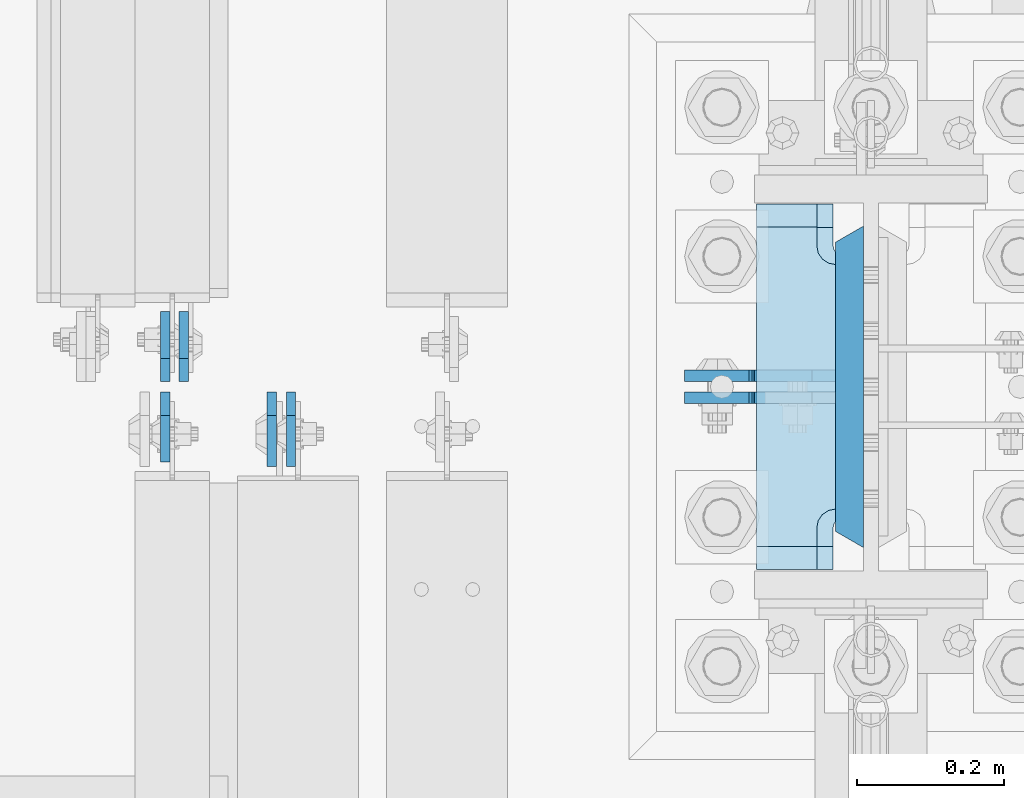
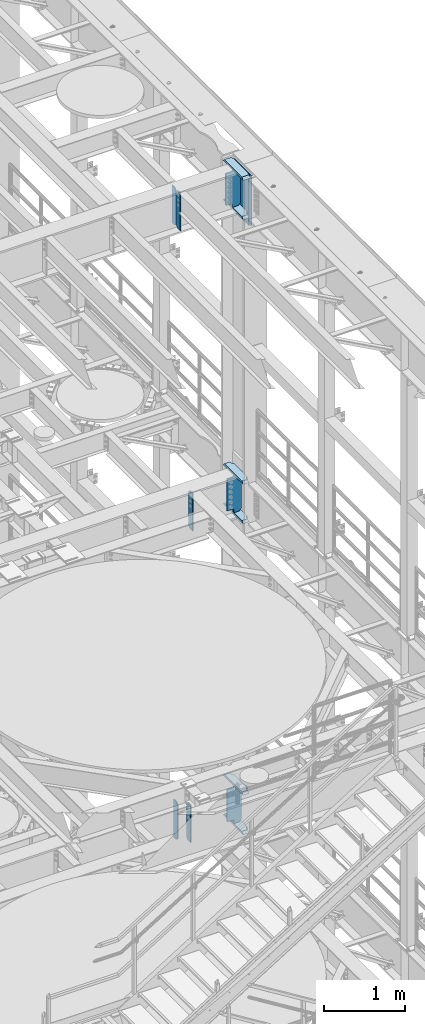
# One storey, part 1591 of 1876: 15 plates, 5 elements without a shape of their own.
"""IFC2X3 building model written with IfcOpenShell, lengths in millimetres."""

from ifc_helpers import new_model, si_unit, frame, origin_with_axes, place, context, subcontext, project, spatial, faceted_brep, material, type_object, element, aggregate, save


model = new_model("IFC2X3")

# Units and contexts
model_context = context("Model", 3, precision=1e-05, world=origin_with_axes())
body_context = subcontext(model_context, "Body", "Model", "MODEL_VIEW")
ifc_project = project(units=[si_unit("LENGTHUNIT", "METRE", prefix="MILLI"), si_unit("AREAUNIT", "SQUARE_METRE"), si_unit("VOLUMEUNIT", "CUBIC_METRE"), si_unit("MASSUNIT", "GRAM", prefix="KILO"), si_unit("TIMEUNIT", "SECOND"), si_unit("PLANEANGLEUNIT", "RADIAN"), si_unit("SOLIDANGLEUNIT", "STERADIAN"), si_unit("THERMODYNAMICTEMPERATUREUNIT", "DEGREE_CELSIUS"), si_unit("LUMINOUSINTENSITYUNIT", "LUMEN")], contexts=[model_context])

# Site, building, storey
site_placement = place(None, origin_with_axes())
site = spatial("IfcSite", under=ifc_project, at=site_placement, CompositionType="ELEMENT")
building_placement = place(site_placement, origin_with_axes())
building = spatial("IfcBuilding", under=site, at=building_placement, Name="Undefined", CompositionType="ELEMENT")
storey_placement = place(building_placement, origin_with_axes())
storey = spatial("IfcBuildingStorey", under=building, at=storey_placement, Name="Undefined", CompositionType="ELEMENT", Elevation=0.0)

# Assembly, plate
assembly_1_placement = place(storey_placement, origin_with_axes())
assembly_1 = element("IfcElementAssembly", 1, at=assembly_1_placement, inside=storey, Name="BEAM", AssemblyPlace="NOTDEFINED", PredefinedType="RIGID_FRAME")
ifc_material_1 = material(Name="STEEL/A36")
plate_type_1 = type_object("IfcPlateType", PredefinedType="NOTDEFINED")
plate_1_placement = place(assembly_1_placement, frame((6683.37499990463, 1531.14375, 12714.2875), z_axis=(0.0, 0.0, 1.0), x_axis=(0.0, 1.0, 0.0)))
plate_1 = element("IfcPlate", 2, at=plate_1_placement, type_object=plate_type_1, material=ifc_material_1, Name="PLATE", context=body_context, shape_type="Brep", body=[
    faceted_brep([(0.0, -6.34999999999991, 31.75), (0.0, -6.35000000000036, 538.162475585938), (0.0, 6.35000000000036, 538.162475585938), (0.0, 6.34999999999991, 31.75), (31.75, -6.35000000000036, 569.912475585938), (31.75, 6.35000000000036, 569.912475585938), (95.25, -6.35000000000036, 569.912475585938), (95.25, 6.35000000000036, 569.912475585938), (95.25, -6.35000000000036, 0.0), (95.25, 6.35000000000036, 0.0), (31.75, -6.34999999999991, 0.0), (31.75, 6.34999999999991, 0.0)], [[[0, 1, 2, 3]], [[1, 4, 5, 2]], [[4, 6, 7, 5]], [[6, 8, 9, 7]], [[8, 10, 11, 9]], [[10, 0, 3, 11]], [[5, 7, 9, 11, 3, 2]], [[10, 8, 6, 4, 1, 0]]]),
])

# Assembly, plates
assembly_2_placement = place(storey_placement, origin_with_axes())
assembly_2 = element("IfcElementAssembly", 3, at=assembly_2_placement, inside=storey, Name="BEAM", AssemblyPlace="NOTDEFINED", PredefinedType="RIGID_FRAME")
plate_2_placement = place(assembly_2_placement, frame((6657.97499990463, 1531.14375, 21959.8875), z_axis=(0.0, 0.0, 1.0), x_axis=(0.0, 1.0, 0.0)))
plate_2 = element("IfcPlate", 4, at=plate_2_placement, type_object=plate_type_1, material=ifc_material_1, Name="PLATE", context=body_context, shape_type="Brep", body=[
    faceted_brep([(0.0, -6.34999999999991, 31.75), (0.0, -6.35000000000036, 538.162475585938), (0.0, 6.35000000000036, 538.162475585938), (0.0, 6.34999999999991, 31.75), (31.75, -6.35000000000036, 569.912475585938), (31.75, 6.35000000000036, 569.912475585938), (95.25, -6.35000000000036, 569.912475585938), (95.25, 6.35000000000036, 569.912475585938), (95.25, -6.35000000000036, 0.0), (95.25, 6.35000000000036, 0.0), (31.75, -6.34999999999991, 0.0), (31.75, 6.34999999999991, 0.0)], [[[0, 1, 2, 3]], [[1, 4, 5, 2]], [[4, 6, 7, 5]], [[6, 8, 9, 7]], [[8, 10, 11, 9]], [[10, 0, 3, 11]], [[5, 7, 9, 11, 3, 2]], [[10, 8, 6, 4, 1, 0]]]),
])
plate_3_placement = place(assembly_2_placement, frame((6657.97499990463, 1516.85625, 21959.8875), z_axis=(0.0, 0.0, 1.0), x_axis=(0.0, -1.0, 0.0)))
plate_3 = element("IfcPlate", 5, at=plate_3_placement, type_object=plate_type_1, material=ifc_material_1, Name="PLATE", context=body_context, shape_type="Brep", body=[
    faceted_brep([(0.0, -6.34999999999991, 31.75), (0.0, -6.35000000000036, 538.162475585938), (0.0, 6.35000000000036, 538.162475585938), (0.0, 6.34999999999991, 31.75), (31.75, -6.35000000000036, 569.912475585938), (31.75, 6.35000000000036, 569.912475585938), (95.25, -6.35000000000036, 569.912475585938), (95.25, 6.35000000000036, 569.912475585938), (95.25, -6.35000000000036, 0.0), (95.25, 6.35000000000036, 0.0), (31.75, -6.34999999999991, 0.0), (31.75, 6.34999999999991, 0.0)], [[[0, 1, 2, 3]], [[1, 4, 5, 2]], [[4, 6, 7, 5]], [[6, 8, 9, 7]], [[8, 10, 11, 9]], [[10, 0, 3, 11]], [[5, 7, 9, 11, 3, 2]], [[10, 8, 6, 4, 1, 0]]]),
])
aggregate(assembly_2, [plate_2, plate_3])

# Plate
plate_type_2 = type_object("IfcPlateType", PredefinedType="NOTDEFINED")
plate_4_placement = place(assembly_1_placement, frame((6803.23124990463, 1516.85625, 12714.2875), z_axis=(0.0, 0.0, 1.0), x_axis=(0.0, -1.0, 0.0)))
plate_4 = element("IfcPlate", 6, at=plate_4_placement, type_object=plate_type_2, material=ifc_material_1, Name="PLATE", context=body_context, shape_type="Brep", body=[
    faceted_brep([(0.0, -6.34999999999991, 31.75), (0.0, -6.35000000000036, 538.162475585938), (0.0, 6.35000000000036, 538.162475585938), (0.0, 6.34999999999991, 31.75), (31.75, -6.35000000000036, 569.912475585938), (31.75, 6.35000000000036, 569.912475585938), (101.599998474121, -6.34999999999991, 569.912475585938), (101.599998474121, 6.34999999999991, 569.912475585938), (101.599998474121, -6.35000000000036, 0.0), (101.599998474121, 6.35000000000036, 0.0), (31.75, -6.34999999999991, 0.0), (31.75, 6.34999999999991, 0.0)], [[[0, 1, 2, 3]], [[1, 4, 5, 2]], [[4, 6, 7, 5]], [[6, 8, 9, 7]], [[8, 10, 11, 9]], [[10, 0, 3, 11]], [[5, 7, 9, 11, 3, 2]], [[10, 8, 6, 4, 1, 0]]]),
])

aggregate(assembly_1, [plate_1, plate_4])

# Assembly, plate
assembly_3_placement = place(storey_placement, origin_with_axes())
assembly_3 = element("IfcElementAssembly", 7, at=assembly_3_placement, inside=storey, Name="BEAM", AssemblyPlace="NOTDEFINED", PredefinedType="RIGID_FRAME")
plate_5_placement = place(assembly_3_placement, frame((6829.42481318188, 1516.85625, 17387.8875), z_axis=(0.0, 0.0, 1.0), x_axis=(0.0, -1.0, 0.0)))
plate_5 = element("IfcPlate", 8, at=plate_5_placement, type_object=plate_type_2, material=ifc_material_1, Name="PLATE", context=body_context, shape_type="Brep", body=[
    faceted_brep([(0.0, -6.34999999999991, 31.75), (0.0, -6.35000000000036, 538.162475585938), (0.0, 6.35000000000036, 538.162475585938), (0.0, 6.34999999999991, 31.75), (31.75, -6.35000000000036, 569.912475585938), (31.75, 6.35000000000036, 569.912475585938), (101.599998474121, -6.34999999999991, 569.912475585938), (101.599998474121, 6.34999999999991, 569.912475585938), (101.599998474121, -6.35000000000036, 0.0), (101.599998474121, 6.35000000000036, 0.0), (31.75, -6.34999999999991, 0.0), (31.75, 6.34999999999991, 0.0)], [[[0, 1, 2, 3]], [[1, 4, 5, 2]], [[4, 6, 7, 5]], [[6, 8, 9, 7]], [[8, 10, 11, 9]], [[10, 0, 3, 11]], [[5, 7, 9, 11, 3, 2]], [[10, 8, 6, 4, 1, 0]]]),
])
aggregate(assembly_3, [plate_5])

# Assembly, plates
assembly_4_placement = place(storey_placement, origin_with_axes())
assembly_4 = element("IfcElementAssembly", 9, at=assembly_4_placement, inside=storey, Name="COLUMN", AssemblyPlace="NOTDEFINED", PredefinedType="RIGID_FRAME")
ifc_material_2 = material(Name="STEEL/A572-GR.50")
plate_type_3 = type_object("IfcPlateType", PredefinedType="NOTDEFINED")
plate_6_placement = place(assembly_4_placement, frame((7590.63125, 1304.925, 22523.45), z_axis=(0.0, 1.0, 0.0), x_axis=(0.0, 0.0, -1.0)))
plate_6 = element("IfcPlate", 10, at=plate_6_placement, type_object=plate_type_3, material=ifc_material_2, Name="PLATE", context=body_context, shape_type="Brep", body=[
    faceted_brep([(0.0, 19.0500000000002, 416.152954742277), (0.0, -19.0500000000002, 438.149993896484), (742.950012207031, -19.0500000000002, 438.149993896484), (742.950012207031, 19.0500000000002, 416.152954742277), (742.950012207031, 19.0500000000002, 21.9970452577325), (0.0, 19.0500000000002, 21.9970452577367), (0.0, -19.0500000000002, 0.0), (742.950012207031, -19.0500000000002, 0.0)], [[[0, 1, 2, 3]], [[0, 3, 4, 5]], [[1, 0, 5, 6]], [[2, 1, 6, 7]], [[3, 2, 7, 4]], [[6, 5, 4, 7]]]),
])
ifc_material_3 = material(Name="STEEL/A572-50")
plate_type_4 = type_object("IfcPlateType", PredefinedType="NOTDEFINED")
plate_7_placement = place(assembly_4_placement, frame((7463.63125, 1773.2375, 17376.775012207), z_axis=(0.0, -1.0, 0.0), x_axis=(1.0, 0.0, 0.0)))
plate_7 = element("IfcPlate", 11, at=plate_7_placement, type_object=plate_type_4, material=ifc_material_3, Name="PLATE", context=body_context, shape_type="Brep", body=[
    faceted_brep([(82.5499973297119, -15.875, 498.475006103516), (82.5499973297119, 15.875, 467.025007631571), (0.0, 15.875, 467.025007631571), (0.0, -15.875, 498.475006103516), (82.5499973297119, 15.875, 31.449998471945), (82.5499973297119, -15.875, 0.0), (0.0, -15.875, 0.0), (0.0, 15.875, 31.449998471945), (82.5499973297119, 15.875, 57.1500034332275), (82.5499973297119, -15.875, 57.1500034332275), (84.4834571748879, -15.875, 66.8701624693188), (84.4834571748879, 15.875, 66.8701624693188), (89.9894849758439, -15.875, 75.1105154056261), (89.9894849758439, 15.875, 75.1105154056261), (98.2298379121512, -15.875, 80.616543206582), (98.2298379121512, 15.875, 80.616543206582), (107.949996948242, -15.875, 82.5500030517578), (107.949996948242, 15.875, 82.5500030517578), (107.949996948242, -15.875, 415.925003051758), (107.949996948242, 15.875, 415.925003051758), (98.2298379121512, -15.875, 417.858462896934), (98.2298379121512, 15.875, 417.858462896934), (89.9894849758439, -15.875, 423.36449069789), (89.9894849758439, 15.875, 423.36449069789), (84.483457174887, -15.875, 431.604843634197), (84.483457174887, 15.875, 431.604843634197), (82.5499973297119, -15.875, 441.325002670288), (82.5499973297119, 15.875, 441.325002670288)], [[[0, 1, 2, 3]], [[4, 5, 6, 7]], [[8, 9, 5, 4]], [[10, 9, 8, 11]], [[12, 10, 11, 13]], [[14, 12, 13, 15]], [[16, 14, 15, 17]], [[18, 16, 17, 19]], [[20, 18, 19, 21]], [[22, 20, 21, 23]], [[24, 22, 23, 25]], [[26, 24, 25, 27]], [[6, 5, 9, 10, 12, 14, 16, 18, 20, 22, 24, 26, 0, 3]], [[7, 6, 3, 2]], [[27, 25, 23, 21, 19, 17, 15, 13, 11, 8, 4, 7, 2, 1]], [[26, 27, 1, 0]]]),
])
plate_8_placement = place(assembly_4_placement, frame((7463.63125, 1773.2375, 17967.325), z_axis=(0.0, -1.0, 0.0), x_axis=(1.0, 0.0, 0.0)))
plate_8 = element("IfcPlate", 12, at=plate_8_placement, type_object=plate_type_4, material=ifc_material_3, Name="PLATE", context=body_context, shape_type="Brep", body=[
    faceted_brep([(82.5499973297119, -15.875, 498.475006103516), (82.5499973297119, 15.875, 467.025007631571), (0.0, 15.875, 467.025007631571), (0.0, -15.875, 498.475006103516), (82.5499973297119, 15.875, 31.449998471945), (82.5499973297119, -15.875, 0.0), (0.0, -15.875, 0.0), (0.0, 15.875, 31.449998471945), (82.5499973297119, 15.875, 57.1500034332275), (82.5499973297119, -15.875, 57.1500034332275), (84.4834571748879, -15.875, 66.8701624693188), (84.4834571748879, 15.875, 66.8701624693188), (89.9894849758439, -15.875, 75.1105154056261), (89.9894849758439, 15.875, 75.1105154056261), (98.2298379121512, -15.875, 80.616543206582), (98.2298379121512, 15.875, 80.616543206582), (107.949996948242, -15.875, 82.5500030517578), (107.949996948242, 15.875, 82.5500030517578), (107.949996948242, -15.875, 415.925003051758), (107.949996948242, 15.875, 415.925003051758), (98.2298379121512, -15.875, 417.858462896934), (98.2298379121512, 15.875, 417.858462896934), (89.9894849758439, -15.875, 423.36449069789), (89.9894849758439, 15.875, 423.36449069789), (84.483457174887, -15.875, 431.604843634197), (84.483457174887, 15.875, 431.604843634197), (82.5499973297119, -15.875, 441.325002670288), (82.5499973297119, 15.875, 441.325002670288)], [[[0, 1, 2, 3]], [[4, 5, 6, 7]], [[8, 9, 5, 4]], [[10, 9, 8, 11]], [[12, 10, 11, 13]], [[14, 12, 13, 15]], [[16, 14, 15, 17]], [[18, 16, 17, 19]], [[20, 18, 19, 21]], [[22, 20, 21, 23]], [[24, 22, 23, 25]], [[26, 24, 25, 27]], [[6, 5, 9, 10, 12, 14, 16, 18, 20, 22, 24, 26, 0, 3]], [[7, 6, 3, 2]], [[27, 25, 23, 21, 19, 17, 15, 13, 11, 8, 4, 7, 2, 1]], [[26, 27, 1, 0]]]),
])
plate_9_placement = place(assembly_4_placement, frame((7463.63125, 1773.2375, 21948.775012207), z_axis=(0.0, -1.0, 0.0), x_axis=(1.0, 0.0, 0.0)))
plate_9 = element("IfcPlate", 13, at=plate_9_placement, type_object=plate_type_4, material=ifc_material_3, Name="PLATE", context=body_context, shape_type="Brep", body=[
    faceted_brep([(82.5499973297119, -15.875, 498.475006103516), (82.5499973297119, 15.875, 467.025007631571), (0.0, 15.875, 467.025007631571), (0.0, -15.875, 498.475006103516), (82.5499973297119, 15.875, 31.449998471945), (82.5499973297119, -15.875, 0.0), (0.0, -15.875, 0.0), (0.0, 15.875, 31.449998471945), (82.5499973297119, 15.875, 57.1500034332275), (82.5499973297119, -15.875, 57.1500034332275), (84.4834571748879, -15.875, 66.8701624693188), (84.4834571748879, 15.875, 66.8701624693188), (89.9894849758439, -15.875, 75.1105154056261), (89.9894849758439, 15.875, 75.1105154056261), (98.2298379121512, -15.875, 80.616543206582), (98.2298379121512, 15.875, 80.616543206582), (107.949996948242, -15.875, 82.5500030517578), (107.949996948242, 15.875, 82.5500030517578), (107.949996948242, -15.875, 415.925003051758), (107.949996948242, 15.875, 415.925003051758), (98.2298379121512, -15.875, 417.858462896934), (98.2298379121512, 15.875, 417.858462896934), (89.9894849758439, -15.875, 423.36449069789), (89.9894849758439, 15.875, 423.36449069789), (84.483457174887, -15.875, 431.604843634197), (84.483457174887, 15.875, 431.604843634197), (82.5499973297119, -15.875, 441.325002670288), (82.5499973297119, 15.875, 441.325002670288)], [[[0, 1, 2, 3]], [[4, 5, 6, 7]], [[8, 9, 5, 4]], [[10, 9, 8, 11]], [[12, 10, 11, 13]], [[14, 12, 13, 15]], [[16, 14, 15, 17]], [[18, 16, 17, 19]], [[20, 18, 19, 21]], [[22, 20, 21, 23]], [[24, 22, 23, 25]], [[26, 24, 25, 27]], [[6, 5, 9, 10, 12, 14, 16, 18, 20, 22, 24, 26, 0, 3]], [[7, 6, 3, 2]], [[27, 25, 23, 21, 19, 17, 15, 13, 11, 8, 4, 7, 2, 1]], [[26, 27, 1, 0]]]),
])

assembly_5_placement = place(storey_placement, origin_with_axes())
assembly_5 = element("IfcElementAssembly", 14, at=assembly_5_placement, inside=storey, Name="COLUMN", AssemblyPlace="NOTDEFINED", PredefinedType="RIGID_FRAME")
plate_10_placement = place(assembly_5_placement, frame((7463.63125, 1773.2375, 12703.175012207), z_axis=(0.0, -1.0, 0.0), x_axis=(1.0, 0.0, 0.0)))
plate_10 = element("IfcPlate", 15, at=plate_10_placement, type_object=plate_type_4, material=ifc_material_3, Name="PLATE", context=body_context, shape_type="Brep", body=[
    faceted_brep([(82.5499973297119, -15.875, 498.475006103516), (82.5499973297119, 15.875, 467.025007631571), (0.0, 15.875, 467.025007631571), (0.0, -15.875, 498.475006103516), (82.5499973297119, 15.875, 31.449998471945), (82.5499973297119, -15.875, 0.0), (0.0, -15.875, 0.0), (0.0, 15.875, 31.449998471945), (82.5499973297119, 15.875, 57.1500034332275), (82.5499973297119, -15.875, 57.1500034332275), (84.4834571748879, -15.875, 66.8701624693188), (84.4834571748879, 15.875, 66.8701624693188), (89.9894849758439, -15.875, 75.1105154056261), (89.9894849758439, 15.875, 75.1105154056261), (98.2298379121512, -15.875, 80.616543206582), (98.2298379121512, 15.875, 80.616543206582), (107.949996948242, -15.875, 82.5500030517578), (107.949996948242, 15.875, 82.5500030517578), (107.949996948242, -15.875, 415.925003051758), (107.949996948242, 15.875, 415.925003051758), (98.2298379121512, -15.875, 417.858462896934), (98.2298379121512, 15.875, 417.858462896934), (89.9894849758439, -15.875, 423.36449069789), (89.9894849758439, 15.875, 423.36449069789), (84.483457174887, -15.875, 431.604843634197), (84.483457174887, 15.875, 431.604843634197), (82.5499973297119, -15.875, 441.325002670288), (82.5499973297119, 15.875, 441.325002670288)], [[[0, 1, 2, 3]], [[4, 5, 6, 7]], [[8, 9, 5, 4]], [[10, 9, 8, 11]], [[12, 10, 11, 13]], [[14, 12, 13, 15]], [[16, 14, 15, 17]], [[18, 16, 17, 19]], [[20, 18, 19, 21]], [[22, 20, 21, 23]], [[24, 22, 23, 25]], [[26, 24, 25, 27]], [[6, 5, 9, 10, 12, 14, 16, 18, 20, 22, 24, 26, 0, 3]], [[7, 6, 3, 2]], [[27, 25, 23, 21, 19, 17, 15, 13, 11, 8, 4, 7, 2, 1]], [[26, 27, 1, 0]]]),
])
plate_11_placement = place(assembly_5_placement, frame((7463.63125, 1773.2375, 13293.725), z_axis=(0.0, -1.0, 0.0), x_axis=(1.0, 0.0, 0.0)))
plate_11 = element("IfcPlate", 16, at=plate_11_placement, type_object=plate_type_4, material=ifc_material_3, Name="PLATE", context=body_context, shape_type="Brep", body=[
    faceted_brep([(82.5499973297119, -15.875, 498.475006103516), (82.5499973297119, 15.875, 467.025007631571), (0.0, 15.875, 467.025007631571), (0.0, -15.875, 498.475006103516), (82.5499973297119, 15.875, 31.449998471945), (82.5499973297119, -15.875, 0.0), (0.0, -15.875, 0.0), (0.0, 15.875, 31.449998471945), (82.5499973297119, 15.875, 57.1500034332275), (82.5499973297119, -15.875, 57.1500034332275), (84.4834571748879, -15.875, 66.8701624693188), (84.4834571748879, 15.875, 66.8701624693188), (89.9894849758439, -15.875, 75.1105154056261), (89.9894849758439, 15.875, 75.1105154056261), (98.2298379121512, -15.875, 80.616543206582), (98.2298379121512, 15.875, 80.616543206582), (107.949996948242, -15.875, 82.5500030517578), (107.949996948242, 15.875, 82.5500030517578), (107.949996948242, -15.875, 415.925003051758), (107.949996948242, 15.875, 415.925003051758), (98.2298379121512, -15.875, 417.858462896934), (98.2298379121512, 15.875, 417.858462896934), (89.9894849758439, -15.875, 423.36449069789), (89.9894849758439, 15.875, 423.36449069789), (84.483457174887, -15.875, 431.604843634197), (84.483457174887, 15.875, 431.604843634197), (82.5499973297119, -15.875, 441.325002670288), (82.5499973297119, 15.875, 441.325002670288)], [[[0, 1, 2, 3]], [[4, 5, 6, 7]], [[8, 9, 5, 4]], [[10, 9, 8, 11]], [[12, 10, 11, 13]], [[14, 12, 13, 15]], [[16, 14, 15, 17]], [[18, 16, 17, 19]], [[20, 18, 19, 21]], [[22, 20, 21, 23]], [[24, 22, 23, 25]], [[26, 24, 25, 27]], [[6, 5, 9, 10, 12, 14, 16, 18, 20, 22, 24, 26, 0, 3]], [[7, 6, 3, 2]], [[27, 25, 23, 21, 19, 17, 15, 13, 11, 8, 4, 7, 2, 1]], [[26, 27, 1, 0]]]),
])

# Plate
plate_type_5 = type_object("IfcPlateType", PredefinedType="NOTDEFINED")
plate_12_placement = place(assembly_4_placement, frame((7571.58125, 1508.91875, 17951.45), z_axis=(-1.0, 0.0, 0.0), x_axis=(0.0, 0.0, -1.0)))
plate_12 = element("IfcPlate", 17, at=plate_12_placement, type_object=plate_type_5, material=ifc_material_1, Name="PLATE", context=body_context, shape_type="Brep", body=[
    faceted_brep([(501.650012207032, -7.9375, 205.581252728631), (501.650012207032, -7.9375, 123.031246757509), (501.650012207032, 7.9375, 123.031246757509), (501.650012207032, 7.9375, 205.581253051758), (502.61674212962, -7.9375, 118.171167239463), (502.61674212962, 7.9375, 118.171167239463), (505.369756030097, -7.9375, 114.050990771309), (505.369756030097, 7.9375, 114.050990771309), (509.489932498251, -7.9375, 111.297976870831), (509.489932498251, 7.9375, 111.297976870831), (514.350012016297, -7.9375, 110.331246948243), (514.350012016297, 7.9375, 110.331246948243), (558.799987792969, -7.9375, 110.331246948243), (558.799987792969, 7.9375, 110.331246948243), (19.0499992370605, -7.9375, 205.58125), (19.0499992370605, 7.9375, 205.581253051758), (19.0499992370605, 7.9375, 123.031249809265), (19.0499992370605, -7.9375, 123.031249809265), (18.083269314473, 7.9375, 118.17117029122), (18.083269314473, -7.9375, 118.17117029122), (15.3302554139955, 7.9375, 114.050993823066), (15.3302554139955, -7.9375, 114.050993823066), (11.2100789458418, 7.9375, 111.297979922588), (11.2100789458418, -7.9375, 111.297979922588), (6.34999942779541, 7.9375, 110.33125), (6.34999942779541, -7.9375, 110.33125), (0.0, 7.9375, 110.33125), (0.0, -7.9375, 110.33125), (0.0, 7.93749999999999, 31.75), (0.0, -7.93749999999998, 31.75), (31.75, -7.93749999999998, 0.0), (31.75, 7.93749999999999, 0.0), (527.049987792969, -7.93749999999998, 0.0), (527.049987792969, 7.93749999999999, 0.0), (558.799987792969, -7.93749999999998, 31.75), (558.799987792969, 7.93749999999999, 31.75)], [[[0, 1, 2, 3]], [[4, 5, 2, 1]], [[6, 7, 5, 4]], [[8, 9, 7, 6]], [[10, 11, 9, 8]], [[12, 13, 11, 10]], [[14, 15, 16, 17]], [[17, 16, 18, 19]], [[19, 18, 20, 21]], [[21, 20, 22, 23]], [[23, 22, 24, 25]], [[25, 24, 26, 27]], [[28, 29, 27, 26]], [[30, 29, 28, 31]], [[32, 30, 31, 33]], [[34, 32, 33, 35]], [[8, 6, 4, 1, 0, 14, 17, 19, 21, 23, 25, 27, 29, 30, 32, 34, 12, 10]], [[15, 14, 0, 3]], [[35, 33, 31, 28, 26, 24, 22, 20, 18, 16, 15, 3, 2, 5, 7, 9, 11, 13]], [[34, 35, 13, 12]]]),
])

plate_13_placement = place(assembly_4_placement, frame((7571.58125, 1539.08125, 22523.45), z_axis=(-1.0, 0.0, 0.0), x_axis=(0.0, 0.0, -1.0)))
plate_13 = element("IfcPlate", 18, at=plate_13_placement, type_object=plate_type_5, material=ifc_material_1, Name="PLATE", context=body_context, shape_type="Brep", body=[
    faceted_brep([(6.34999942779541, -7.9375, 110.33125), (6.34999942779541, 7.9375, 110.33125), (0.0, 7.9375, 110.33125), (0.0, -7.9375, 110.33125), (11.2100789458418, -7.9375, 111.297979922588), (11.2100789458418, 7.9375, 111.297979922588), (15.3302554139955, -7.9375, 114.050993823066), (15.3302554139955, 7.9375, 114.050993823066), (18.083269314473, -7.9375, 118.17117029122), (18.083269314473, 7.9375, 118.17117029122), (19.0499992370605, -7.9375, 123.031249809265), (19.0499992370605, 7.9375, 123.031249809265), (19.0499992370605, -7.9375, 205.58125), (19.0499992370605, 7.9375, 205.581253051758), (31.75, -7.93749999999998, 0.0), (0.0, -7.93749999999998, 31.75), (0.0, 7.93749999999999, 31.75), (31.75, 7.93749999999999, 0.0), (527.049987792969, -7.93749999999998, 0.0), (527.049987792969, 7.93749999999999, 0.0), (558.799987792969, -7.93749999999998, 31.75), (558.799987792969, 7.93749999999999, 31.75), (558.799987792969, 7.9375, 110.331246948243), (558.722831462172, -7.9375, 110.33125), (514.350012016297, 7.9375, 110.331246948243), (514.350012016297, -7.9375, 110.331246948243), (509.489932498251, 7.9375, 111.297976870831), (509.489932498251, -7.9375, 111.297976870831), (505.369756030097, 7.9375, 114.050990771309), (505.369756030097, -7.9375, 114.050990771309), (502.61674212962, 7.9375, 118.171167239463), (502.61674212962, -7.9375, 118.171167239463), (501.650012207032, 7.9375, 123.031246757509), (501.650012207032, -7.9375, 123.031246757509), (501.650012207032, -7.9375, 205.581252728631), (501.650012207032, 7.9375, 205.581253051758)], [[[0, 1, 2, 3]], [[4, 5, 1, 0]], [[6, 7, 5, 4]], [[8, 9, 7, 6]], [[10, 11, 9, 8]], [[12, 13, 11, 10]], [[14, 15, 16, 17]], [[18, 14, 17, 19]], [[20, 18, 19, 21]], [[20, 21, 22, 23]], [[23, 22, 24, 25]], [[25, 24, 26, 27]], [[27, 26, 28, 29]], [[29, 28, 30, 31]], [[31, 30, 32, 33]], [[34, 33, 32, 35]], [[8, 6, 4, 0, 3, 15, 14, 18, 20, 23, 25, 27, 29, 31, 33, 34, 12, 10]], [[16, 15, 3, 2]], [[21, 19, 17, 16, 2, 1, 5, 7, 9, 11, 13, 35, 32, 30, 28, 26, 24, 22]], [[13, 12, 34, 35]]]),
])

plate_14_placement = place(assembly_5_placement, frame((7571.58125, 1508.91875, 13277.85), z_axis=(-1.0, 0.0, 0.0), x_axis=(0.0, 0.0, -1.0)))
plate_14 = element("IfcPlate", 19, at=plate_14_placement, type_object=plate_type_5, material=ifc_material_1, Name="PLATE", context=body_context, shape_type="Brep", body=[
    faceted_brep([(501.650012207032, -7.9375, 205.581252728631), (501.650012207032, -7.9375, 123.031246757509), (501.650012207032, 7.9375, 123.031246757509), (501.650012207032, 7.9375, 205.581253051758), (502.61674212962, -7.9375, 118.171167239463), (502.61674212962, 7.9375, 118.171167239463), (505.369756030097, -7.9375, 114.050990771309), (505.369756030097, 7.9375, 114.050990771309), (509.489932498251, -7.9375, 111.297976870831), (509.489932498251, 7.9375, 111.297976870831), (514.350012016297, -7.9375, 110.331246948243), (514.350012016297, 7.9375, 110.331246948243), (558.799987792969, -7.9375, 110.331246948243), (558.799987792969, 7.9375, 110.331246948243), (19.0499992370605, -7.9375, 205.58125), (19.0499992370605, 7.9375, 205.581253051758), (19.0499992370605, 7.9375, 123.031249809265), (19.0499992370605, -7.9375, 123.031249809265), (18.083269314473, 7.9375, 118.17117029122), (18.083269314473, -7.9375, 118.17117029122), (15.3302554139955, 7.9375, 114.050993823066), (15.3302554139955, -7.9375, 114.050993823066), (11.2100789458418, 7.9375, 111.297979922588), (11.2100789458418, -7.9375, 111.297979922588), (6.34999942779541, 7.9375, 110.33125), (6.34999942779541, -7.9375, 110.33125), (0.0, 7.9375, 110.33125), (0.0, -7.9375, 110.33125), (0.0, 7.93749999999999, 31.75), (0.0, -7.93749999999998, 31.75), (31.75, -7.93749999999998, 0.0), (31.75, 7.93749999999999, 0.0), (527.049987792969, -7.93749999999998, 0.0), (527.049987792969, 7.93749999999999, 0.0), (558.799987792969, -7.93749999999998, 31.75), (558.799987792969, 7.93749999999999, 31.75)], [[[0, 1, 2, 3]], [[4, 5, 2, 1]], [[6, 7, 5, 4]], [[8, 9, 7, 6]], [[10, 11, 9, 8]], [[12, 13, 11, 10]], [[14, 15, 16, 17]], [[17, 16, 18, 19]], [[19, 18, 20, 21]], [[21, 20, 22, 23]], [[23, 22, 24, 25]], [[25, 24, 26, 27]], [[28, 29, 27, 26]], [[30, 29, 28, 31]], [[32, 30, 31, 33]], [[34, 32, 33, 35]], [[8, 6, 4, 1, 0, 14, 17, 19, 21, 23, 25, 27, 29, 30, 32, 34, 12, 10]], [[15, 14, 0, 3]], [[35, 33, 31, 28, 26, 24, 22, 20, 18, 16, 15, 3, 2, 5, 7, 9, 11, 13]], [[34, 35, 13, 12]]]),
])

aggregate(assembly_5, [plate_10, plate_11, plate_14])

plate_type_6 = type_object("IfcPlateType", PredefinedType="NOTDEFINED")
plate_15_placement = place(assembly_4_placement, frame((7463.63124694824, 1274.7625, 22539.325), z_axis=(0.0, 1.0, 0.0), x_axis=(1.0, 0.0, 0.0)))
plate_15 = element("IfcPlate", 20, at=plate_15_placement, type_object=plate_type_6, material=ifc_material_3, Name="PLATE", context=body_context, shape_type="Brep", body=[
    faceted_brep([(108.494745348945, -15.875, 66.1302546510551), (108.494745348945, 15.875, 66.1302546510551), (112.614921817099, 15.875, 68.8832685515335), (112.614921817099, -15.875, 68.8832685515335), (105.741731448466, -15.875, 62.0100781829015), (105.741731448466, 15.875, 62.0100781829015), (104.775001525879, -15.875, 57.149998664856), (104.775001525879, 15.875, 57.149998664856), (104.775001525879, -15.875, 31.75), (104.775001525879, 15.875, 0.0), (0.0, -15.875, 31.75), (0.0, 15.875, 0.0), (0.0, -15.875, 466.725006103516), (0.0, 15.875, 498.475006103516), (104.775001525879, -15.875, 466.725006103516), (104.775001525879, 15.875, 498.475006103516), (104.775001525879, -15.875, 441.325001335143), (104.775001525879, 15.875, 441.325001335143), (105.741731448466, -15.875, 436.464921817097), (105.741731448466, 15.875, 436.464921817097), (108.494745348945, -15.875, 432.344745348943), (108.494745348945, 15.875, 432.344745348943), (112.614921817099, -15.875, 429.591731448465), (112.614921817099, 15.875, 429.591731448465), (117.475001335144, 15.875, 69.8499984741211), (117.475001335144, 15.875, 428.625001525877), (146.050003051758, 15.875, 428.625001525877), (146.050003051758, 15.875, 69.8499984741211), (117.475001335144, -12.7000017166138, 69.8499984741211), (114.300003051756, -15.875, 69.2184520491464), (114.300003051756, -15.875, 429.256547950852), (117.475001335144, -12.7000017166138, 428.625001525877)], [[[0, 1, 2, 3]], [[4, 5, 1, 0]], [[6, 7, 5, 4]], [[8, 9, 7, 6]], [[10, 11, 9, 8]], [[11, 10, 12, 13]], [[13, 12, 14, 15]], [[15, 14, 16, 17]], [[18, 19, 17, 16]], [[20, 21, 19, 18]], [[22, 23, 21, 20]], [[24, 2, 1, 5, 7, 9, 11, 13, 15, 17, 19, 21, 23, 25, 26, 27]], [[24, 27, 28]], [[3, 2, 24, 28, 29]], [[22, 20, 18, 16, 14, 12, 10, 8, 6, 4, 0, 3, 29, 30]], [[25, 23, 22, 30, 31]], [[25, 31, 26]], [[30, 29, 28, 27, 26, 31]]]),
])

aggregate(assembly_4, [plate_7, plate_8, plate_12, plate_9, plate_13, plate_6, plate_15])

save(model, "model.ifc")
